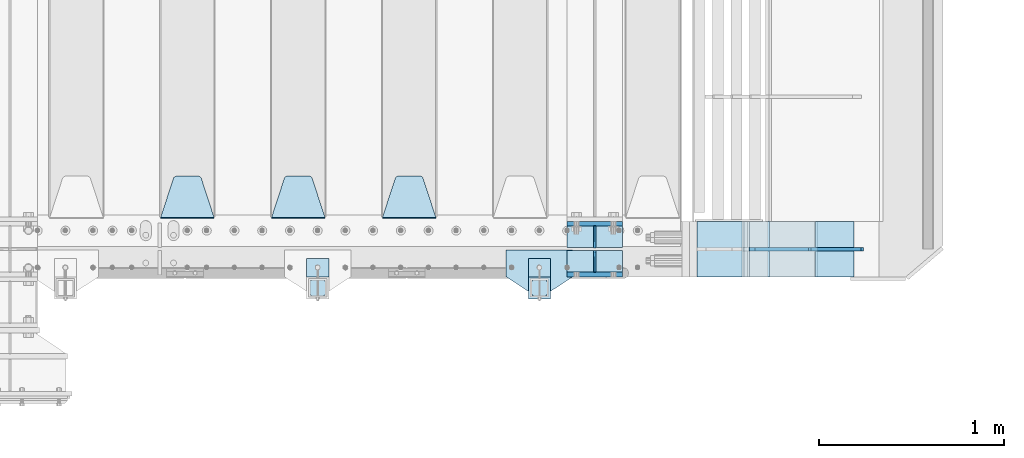
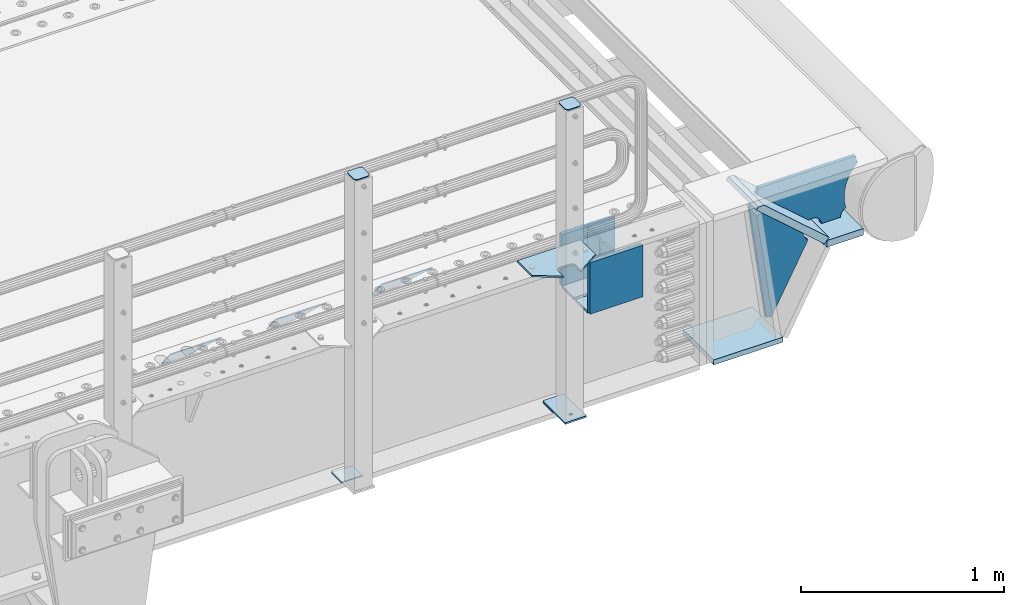
# One storey, part 201 of 240: 20 plates.
"""IFC2X3 building model written with IfcOpenShell, lengths in millimetres."""

from ifc_helpers import new_model, si_unit, frame, origin_with_axes, place, context, subcontext, project, spatial, faceted_brep, material, type_object, element, save


model = new_model("IFC2X3")

# Units and contexts
model_context = context("Model", 3, precision=1e-05, world=origin_with_axes())
body_context = subcontext(model_context, "Body", "Model", "MODEL_VIEW")
ifc_project = project(units=[si_unit("LENGTHUNIT", "METRE", prefix="MILLI"), si_unit("AREAUNIT", "SQUARE_METRE"), si_unit("VOLUMEUNIT", "CUBIC_METRE"), si_unit("MASSUNIT", "GRAM", prefix="KILO"), si_unit("TIMEUNIT", "SECOND"), si_unit("PLANEANGLEUNIT", "RADIAN"), si_unit("SOLIDANGLEUNIT", "STERADIAN"), si_unit("THERMODYNAMICTEMPERATUREUNIT", "DEGREE_CELSIUS"), si_unit("LUMINOUSINTENSITYUNIT", "LUMEN")], contexts=[model_context])

# Site, building, storey
site_placement = place(None, origin_with_axes())
site = spatial("IfcSite", under=ifc_project, at=site_placement, CompositionType="ELEMENT")
building_placement = place(site_placement, origin_with_axes())
building = spatial("IfcBuilding", under=site, at=building_placement, Name="Standard", CompositionType="ELEMENT")
storey_placement = place(building_placement, origin_with_axes())
storey = spatial("IfcBuildingStorey", under=building, at=storey_placement, Name="Undefined", CompositionType="ELEMENT", Elevation=0.0)

# Plates
ifc_material_1 = material(Name="STEEL/S355N")
plate_type_1 = type_object("IfcPlateType", PredefinedType="NOTDEFINED")
for number, where, z_axis, x_axis in (
    (1, (55855.0, 23862.5, -339.999999999995), (0.0, 0.0, 1.0), (1.0, 0.0, 0.0)),
    (2, (55855.0, 24137.5, -339.999999999995), (0.0, 0.0, 1.0), (1.0, 0.0, 0.0)),
):
    element("IfcPlate", number, at=place(storey_placement, frame(where, z_axis=z_axis, x_axis=x_axis)), inside=storey, type_object=plate_type_1, material=ifc_material_1, context=body_context, shape_type="Brep", body=[
        faceted_brep([(0.0, -12.5, 0.0), (0.0, -12.5, 310.0), (0.0, 12.5, 310.0), (0.0, 12.5, 0.0), (300.0, -12.5, 310.0), (300.0, 12.5, 310.0), (300.0, -12.5, 0.0), (300.0, 12.5, 0.0)], [[[0, 1, 2, 3]], [[1, 4, 5, 2]], [[4, 6, 7, 5]], [[6, 0, 3, 7]], [[5, 7, 3, 2]], [[6, 4, 1, 0]]]),
    ])
plate_type_2 = type_object("IfcPlateType", PredefinedType="NOTDEFINED")
for number, where, z_axis, x_axis in (
    (3, (55855.0, 24008.0, -342.999999999995), (0.0, 1.0, 0.0), (1.0, 0.0, 0.0)),
    (4, (55855.0, 23992.0, -342.999999999995), (0.0, -1.0, 0.0), (1.0, 0.0, 0.0)),
):
    element("IfcPlate", number, at=place(storey_placement, frame(where, z_axis=z_axis, x_axis=x_axis)), inside=storey, type_object=plate_type_2, material=ifc_material_1, context=body_context, shape_type="Brep", body=[
        faceted_brep([(0.0, -7.0, 0.0), (0.0, -7.0, 117.0), (0.0, 7.0, 117.0), (0.0, 7.0, 0.0), (300.0, -7.0, 117.0), (300.0, 7.0, 117.0), (300.0, -7.0, 0.0), (300.0, 7.0, 0.0)], [[[0, 1, 2, 3]], [[1, 4, 5, 2]], [[4, 6, 7, 5]], [[6, 0, 3, 7]], [[5, 7, 3, 2]], [[6, 4, 1, 0]]]),
    ])
plate_type_3 = type_object("IfcPlateType", PredefinedType="NOTDEFINED")
for number, where, z_axis, x_axis in (
    (5, (56005.0, 23992.0, -29.9999999999945), (0.0, 0.0, -1.0), (0.0, -1.0, 0.0)),
    (6, (56005.0, 24008.0, -29.9999999999945), (0.0, 0.0, -1.0), (0.0, 1.0, 0.0)),
):
    element("IfcPlate", number, at=place(storey_placement, frame(where, z_axis=z_axis, x_axis=x_axis)), inside=storey, type_object=plate_type_3, material=ifc_material_1, context=body_context, shape_type="Brep", body=[
        faceted_brep([(0.0, -5.0, 30.0), (0.0, -5.0, 306.0), (0.0, 5.0, 306.0), (0.0, 5.0, 30.0), (117.0, -5.0, 306.0), (117.0, 5.0, 306.0), (117.0, -5.0, 0.0), (117.0, 5.0, 0.0), (30.0, -5.0, 0.0), (30.0, 5.0, 0.0), (24.7905546699913, -5.0, 0.455767409633758), (24.7905546699913, 5.0, 0.455767409633758), (19.7393957002278, -5.0, 1.80922137642275), (19.7393957002278, 5.0, 1.80922137642275), (15.0, -5.0, 4.01923788646684), (15.0, 5.0, 4.01923788646684), (10.7163717094008, -5.0, 7.01866670643066), (10.7163717094008, 5.0, 7.01866670643066), (7.01866670643358, -5.0, 10.7163717094038), (7.01866670643358, 5.0, 10.7163717094038), (4.01923788646673, -5.0, 15.0), (4.01923788646673, 5.0, 15.0), (1.80922137642483, -5.0, 19.7393957002299), (1.80922137642483, 5.0, 19.7393957002299), (0.455767409635882, -5.0, 24.7905546699921), (0.455767409635882, 5.0, 24.7905546699921)], [[[0, 1, 2, 3]], [[1, 4, 5, 2]], [[4, 6, 7, 5]], [[6, 8, 9, 7]], [[8, 10, 11, 9]], [[10, 12, 13, 11]], [[12, 14, 15, 13]], [[14, 16, 17, 15]], [[16, 18, 19, 17]], [[18, 20, 21, 19]], [[20, 22, 23, 21]], [[22, 24, 25, 23]], [[24, 0, 3, 25]], [[5, 7, 9, 11, 13, 15, 17, 19, 21, 23, 25, 3, 2]], [[24, 22, 20, 18, 16, 14, 12, 10, 8, 6, 4, 1, 0]]]),
    ])
plate_type_4 = type_object("IfcPlateType", PredefinedType="NOTDEFINED")
plate_1_placement = place(storey_placement, frame((55145.0, 24168.232233047, -1.76776695296758), z_axis=(0.0, 0.707106781186547, -0.707106781186548), x_axis=(-1.0, 0.0, 0.0)))
element("IfcPlate", 7, at=plate_1_placement, inside=storey, type_object=plate_type_4, material=ifc_material_1, context=body_context, shape_type="Brep", body=[
    faceted_brep([(0.0, -2.5, 0.0), (69.345504679477, -2.50000000000364, 300.171731424827), (69.345504679477, 2.49999999999636, 300.171731424827), (0.0, 2.5, 0.0), (70.927406119954, -2.50000000000364, 304.897442415397), (70.927406119954, 2.49999999999636, 304.897442415397), (73.3818627772271, -2.50000000000728, 309.234538108525), (73.3818627772271, 2.49999999999636, 309.234538108529), (76.6187032999587, -2.50000000000728, 313.023683126099), (76.6187032999587, 2.49999999999636, 313.023683126103), (80.5190132705029, -2.50000000000364, 316.125672595368), (80.5190132705029, 2.49999999999636, 316.125672595368), (84.9395038596849, -2.50000000000364, 318.426546230472), (84.9395038596849, 2.49999999999636, 318.426546230472), (89.7177759439219, -2.5, 319.841774983277), (89.7177759439219, 2.49999999999636, 319.841774983273), (94.6782862926484, -2.50000000000364, 320.319366455074), (94.6782862926484, 2.49999999999636, 320.319366455074), (195.321713707352, -2.50000000000364, 320.319366455074), (195.321713707352, 2.49999999999636, 320.319366455074), (200.282224056078, -2.50000000000364, 319.841774983273), (200.282224056078, 2.49999999999636, 319.841774983273), (205.060496140315, -2.50000000000364, 318.426546230472), (205.060496140315, 2.49999999999636, 318.426546230472), (209.480986729497, -2.50000000000364, 316.125672595368), (209.480986729497, 2.49999999999636, 316.125672595368), (213.381296700041, -2.50000000000728, 313.023683126099), (213.381296700041, 2.49999999999272, 313.023683126099), (216.618137222766, -2.50000000000364, 309.234538108522), (216.618137222766, 2.49999999999636, 309.234538108522), (219.072593880039, -2.50000000000364, 304.897442415397), (219.072593880039, 2.49999999999636, 304.897442415397), (220.654495320523, -2.50000000000364, 300.171731424827), (220.654495320523, 2.49999999999636, 300.171731424827), (290.0, -2.50000000000364, -3.63797880709171e-12), (290.0, 2.49999999999636, -3.63797880709171e-12)], [[[0, 1, 2, 3]], [[1, 4, 5, 2]], [[4, 6, 7, 5]], [[6, 8, 9, 7]], [[8, 10, 11, 9]], [[10, 12, 13, 11]], [[12, 14, 15, 13]], [[14, 16, 17, 15]], [[16, 18, 19, 17]], [[18, 20, 21, 19]], [[20, 22, 23, 21]], [[22, 24, 25, 23]], [[24, 26, 27, 25]], [[26, 28, 29, 27]], [[28, 30, 31, 29]], [[30, 32, 33, 31]], [[32, 34, 35, 33]], [[34, 0, 3, 35]], [[5, 7, 9, 11, 13, 15, 17, 19, 21, 23, 25, 27, 29, 31, 33, 35, 3, 2]], [[34, 32, 30, 28, 26, 24, 22, 20, 18, 16, 14, 12, 10, 8, 6, 4, 1, 0]]]),
])
plate_2_placement = place(storey_placement, frame((54545.0, 24168.232233047, -1.76776695296758), z_axis=(0.0, 0.707106781186547, -0.707106781186548), x_axis=(-1.0, 0.0, 0.0)))
element("IfcPlate", 8, at=plate_2_placement, inside=storey, type_object=plate_type_4, material=ifc_material_1, context=body_context, shape_type="Brep", body=[
    faceted_brep([(0.0, -2.5, 0.0), (69.345504679477, -2.50000000000364, 300.171731424827), (69.345504679477, 2.49999999999636, 300.171731424827), (0.0, 2.5, 0.0), (70.927406119954, -2.50000000000364, 304.897442415397), (70.927406119954, 2.49999999999636, 304.897442415397), (73.3818627772271, -2.50000000000728, 309.234538108525), (73.3818627772271, 2.49999999999636, 309.234538108529), (76.6187032999587, -2.50000000000728, 313.023683126099), (76.6187032999587, 2.49999999999636, 313.023683126103), (80.5190132705029, -2.50000000000364, 316.125672595368), (80.5190132705029, 2.49999999999636, 316.125672595368), (84.9395038596849, -2.50000000000364, 318.426546230472), (84.9395038596849, 2.49999999999636, 318.426546230472), (89.7177759439219, -2.5, 319.841774983277), (89.7177759439219, 2.49999999999636, 319.841774983273), (94.6782862926484, -2.50000000000364, 320.319366455074), (94.6782862926484, 2.49999999999636, 320.319366455074), (195.321713707352, -2.50000000000364, 320.319366455074), (195.321713707352, 2.49999999999636, 320.319366455074), (200.282224056078, -2.50000000000364, 319.841774983273), (200.282224056078, 2.49999999999636, 319.841774983273), (205.060496140315, -2.50000000000364, 318.426546230472), (205.060496140315, 2.49999999999636, 318.426546230472), (209.480986729497, -2.50000000000364, 316.125672595368), (209.480986729497, 2.49999999999636, 316.125672595368), (213.381296700041, -2.50000000000728, 313.023683126099), (213.381296700041, 2.49999999999272, 313.023683126099), (216.618137222766, -2.50000000000364, 309.234538108522), (216.618137222766, 2.49999999999636, 309.234538108522), (219.072593880039, -2.50000000000364, 304.897442415397), (219.072593880039, 2.49999999999636, 304.897442415397), (220.654495320523, -2.50000000000364, 300.171731424827), (220.654495320523, 2.49999999999636, 300.171731424827), (290.0, -2.50000000000364, -3.63797880709171e-12), (290.0, 2.49999999999636, -3.63797880709171e-12)], [[[0, 1, 2, 3]], [[1, 4, 5, 2]], [[4, 6, 7, 5]], [[6, 8, 9, 7]], [[8, 10, 11, 9]], [[10, 12, 13, 11]], [[12, 14, 15, 13]], [[14, 16, 17, 15]], [[16, 18, 19, 17]], [[18, 20, 21, 19]], [[20, 22, 23, 21]], [[22, 24, 25, 23]], [[24, 26, 27, 25]], [[26, 28, 29, 27]], [[28, 30, 31, 29]], [[30, 32, 33, 31]], [[32, 34, 35, 33]], [[34, 0, 3, 35]], [[5, 7, 9, 11, 13, 15, 17, 19, 21, 23, 25, 27, 29, 31, 33, 35, 3, 2]], [[34, 32, 30, 28, 26, 24, 22, 20, 18, 16, 14, 12, 10, 8, 6, 4, 1, 0]]]),
])
plate_3_placement = place(storey_placement, frame((53945.0, 24168.232233047, -1.76776695296758), z_axis=(0.0, 0.707106781186547, -0.707106781186548), x_axis=(-1.0, 0.0, 0.0)))
element("IfcPlate", 9, at=plate_3_placement, inside=storey, type_object=plate_type_4, material=ifc_material_1, context=body_context, shape_type="Brep", body=[
    faceted_brep([(0.0, -2.5, 0.0), (69.345504679477, -2.50000000000364, 300.171731424827), (69.345504679477, 2.49999999999636, 300.171731424827), (0.0, 2.5, 0.0), (70.927406119954, -2.50000000000364, 304.897442415397), (70.927406119954, 2.49999999999636, 304.897442415397), (73.3818627772271, -2.50000000000728, 309.234538108525), (73.3818627772271, 2.49999999999636, 309.234538108529), (76.6187032999587, -2.50000000000728, 313.023683126099), (76.6187032999587, 2.49999999999636, 313.023683126103), (80.5190132705029, -2.50000000000364, 316.125672595368), (80.5190132705029, 2.49999999999636, 316.125672595368), (84.9395038596849, -2.50000000000364, 318.426546230472), (84.9395038596849, 2.49999999999636, 318.426546230472), (89.7177759439219, -2.5, 319.841774983277), (89.7177759439219, 2.49999999999636, 319.841774983273), (94.6782862926484, -2.50000000000364, 320.319366455074), (94.6782862926484, 2.49999999999636, 320.319366455074), (195.321713707352, -2.50000000000364, 320.319366455074), (195.321713707352, 2.49999999999636, 320.319366455074), (200.282224056078, -2.50000000000364, 319.841774983273), (200.282224056078, 2.49999999999636, 319.841774983273), (205.060496140315, -2.50000000000364, 318.426546230472), (205.060496140315, 2.49999999999636, 318.426546230472), (209.480986729497, -2.50000000000364, 316.125672595368), (209.480986729497, 2.49999999999636, 316.125672595368), (213.381296700041, -2.50000000000728, 313.023683126099), (213.381296700041, 2.49999999999272, 313.023683126099), (216.618137222766, -2.50000000000364, 309.234538108522), (216.618137222766, 2.49999999999636, 309.234538108522), (219.072593880039, -2.50000000000364, 304.897442415397), (219.072593880039, 2.49999999999636, 304.897442415397), (220.654495320523, -2.50000000000364, 300.171731424827), (220.654495320523, 2.49999999999636, 300.171731424827), (290.0, -2.50000000000364, -3.63797880709171e-12), (290.0, 2.49999999999636, -3.63797880709171e-12)], [[[0, 1, 2, 3]], [[1, 4, 5, 2]], [[4, 6, 7, 5]], [[6, 8, 9, 7]], [[8, 10, 11, 9]], [[10, 12, 13, 11]], [[12, 14, 15, 13]], [[14, 16, 17, 15]], [[16, 18, 19, 17]], [[18, 20, 21, 19]], [[20, 22, 23, 21]], [[22, 24, 25, 23]], [[24, 26, 27, 25]], [[26, 28, 29, 27]], [[28, 30, 31, 29]], [[30, 32, 33, 31]], [[32, 34, 35, 33]], [[34, 0, 3, 35]], [[5, 7, 9, 11, 13, 15, 17, 19, 21, 23, 25, 27, 29, 31, 33, 35, 3, 2]], [[34, 32, 30, 28, 26, 24, 22, 20, 18, 16, 14, 12, 10, 8, 6, 4, 1, 0]]]),
])
plate_type_5 = type_object("IfcPlateType", PredefinedType="NOTDEFINED")
plate_4_placement = place(storey_placement, frame((57198.9988298899, 24149.9999999992, -367.999999998666), z_axis=(-0.752989422949573, 0.0, 0.658032619955933), x_axis=(0.0, -1.0, 0.0)))
element("IfcPlate", 10, at=plate_4_placement, inside=storey, type_object=plate_type_5, material=ifc_material_1, context=body_context, shape_type="Brep", body=[
    faceted_brep([(-8.11269273981452e-10, 19.9999999999927, 490.766265601618), (0.0, -0.303811250945728, 514.0), (300.0, -0.303811250945728, 514.0), (300.0, 19.9999999999927, 490.766265601618), (300.0, -20.0, -1.81898940354586e-12), (300.0, -20.0, 514.0), (0.0, -20.0, 514.0), (0.0, -20.0, 0.0), (0.0, 20.0, 0.0), (300.0, 20.0, -1.81898940354586e-12)], [[[0, 1, 2, 3]], [[4, 5, 6, 7]], [[4, 7, 8, 9]], [[9, 8, 0, 3]], [[5, 4, 9, 3, 2]], [[6, 5, 2, 1]], [[8, 7, 6, 1, 0]]]),
])
ifc_material_2 = material(Name="STEEL/S355J2")
plate_type_6 = type_object("IfcPlateType", PredefinedType="NOTDEFINED")
plate_5_placement = place(storey_placement, frame((55885.0, 23995.0, 5.00000000004911), z_axis=(0.0, -1.0, 0.0), x_axis=(-1.0, 0.0, 0.0)))
element("IfcPlate", 11, at=plate_5_placement, inside=storey, type_object=plate_type_6, material=ifc_material_2, context=body_context, shape_type="Brep", body=[
    faceted_brep([(0.0, -5.0, 0.0), (2.31396552408114e-06, -5.0, 145.0), (2.31396552408114e-06, 5.0, 145.0), (0.0, 5.0, 0.0), (130.0, -5.0, 230.0), (130.0, 5.0, 230.0), (130.0, -5.0, 180.0), (130.0, 5.0, 180.0), (130.48036798992, -5.0, 175.122741949599), (130.48036798992, 5.0, 175.122741949599), (131.903011687216, -5.0, 170.432914190875), (131.903011687216, 5.0, 170.432914190875), (134.213259692435, -5.0, 166.110744174512), (134.213259692435, 5.0, 166.110744174512), (137.322330470335, -5.0, 162.322330470335), (137.322330470335, 5.0, 162.322330470335), (141.110744174512, -5.0, 159.213259692435), (141.110744174512, 5.0, 159.213259692435), (145.432914190875, -5.0, 156.903011687216), (145.432914190875, 5.0, 156.903011687216), (150.122741949599, -5.0, 155.48036798992), (150.122741949599, 5.0, 155.48036798992), (155.0, -5.0, 155.0), (155.0, 5.0, 155.0), (205.0, -5.0, 155.0), (205.0, 5.0, 155.0), (209.877258050401, -5.0, 155.48036798992), (209.877258050401, 5.0, 155.48036798992), (214.567085809125, -5.0, 156.903011687216), (214.567085809125, 5.0, 156.903011687216), (218.889255825488, -5.0, 159.213259692435), (218.889255825488, 5.0, 159.213259692435), (222.677669529665, -5.0, 162.322330470335), (222.677669529665, 5.0, 162.322330470335), (225.786740307565, -5.0, 166.110744174512), (225.786740307565, 5.0, 166.110744174512), (228.096988312784, -5.0, 170.432914190875), (228.096988312784, 5.0, 170.432914190875), (229.51963201008, -5.0, 175.122741949599), (229.51963201008, 5.0, 175.122741949599), (230.0, -5.0, 180.0), (230.0, 5.0, 180.0), (230.0, -5.0, 230.0), (230.0, 5.0, 230.0), (360.0, -5.0, 145.0), (360.0, 5.0, 145.0), (360.0, -5.0, -7.27595761418343e-12), (360.0, 5.0, -7.27595761418343e-12)], [[[0, 1, 2, 3]], [[1, 4, 5, 2]], [[4, 6, 7, 5]], [[6, 8, 9, 7]], [[8, 10, 11, 9]], [[10, 12, 13, 11]], [[12, 14, 15, 13]], [[14, 16, 17, 15]], [[16, 18, 19, 17]], [[18, 20, 21, 19]], [[20, 22, 23, 21]], [[22, 24, 25, 23]], [[24, 26, 27, 25]], [[26, 28, 29, 27]], [[28, 30, 31, 29]], [[30, 32, 33, 31]], [[32, 34, 35, 33]], [[34, 36, 37, 35]], [[36, 38, 39, 37]], [[38, 40, 41, 39]], [[40, 42, 43, 41]], [[42, 44, 45, 43]], [[44, 46, 47, 45]], [[46, 0, 3, 47]], [[5, 7, 9, 11, 13, 15, 17, 19, 21, 23, 25, 27, 29, 31, 33, 35, 37, 39, 41, 43, 45, 47, 3, 2]], [[46, 44, 42, 40, 38, 36, 34, 32, 30, 28, 26, 24, 22, 20, 18, 16, 14, 12, 10, 8, 6, 4, 1, 0]]]),
])
plate_type_7 = type_object("IfcPlateType", PredefinedType="NOTDEFINED")
plate_6_placement = place(storey_placement, frame((55764.9999999999, 23949.9999999998, -850.000000000002), z_axis=(0.0, -1.0, 0.0), x_axis=(-1.0, 0.0, 0.0)))
element("IfcPlate", 12, at=plate_6_placement, inside=storey, type_object=plate_type_7, material=ifc_material_2, context=body_context, shape_type="Brep", body=[
    faceted_brep([(53.6360389691836, -5.0, 176.363961030467), (53.6360389691836, 5.0, 176.363961030467), (59.9999999998618, 5.0, 178.999999999789), (59.9999999998618, -5.0, 178.999999999789), (66.3639610305399, 5.0, 176.363961030467), (66.3639610305399, -5.0, 176.363961030467), (68.9999999998618, 5.0, 169.999999999789), (68.9999999998618, -5.0, 169.999999999789), (66.3639610305399, 5.0, 163.636038969111), (66.3639610305399, -5.0, 163.636038969111), (59.9999999998618, 5.0, 160.999999999789), (59.9999999998618, -5.0, 160.999999999789), (53.6360389691836, 5.0, 163.636038969111), (53.6360389691836, -5.0, 163.636038969111), (50.9999999998618, 5.0, 169.999999999789), (50.9999999998618, -5.0, 169.999999999789), (120.0, -5.0, 0.0), (120.0, -5.0, 220.0), (0.0, -5.0, 220.0), (0.0, -5.0, 0.0), (0.0, 5.0, 0.0), (120.0, 5.0, 0.0), (120.0, 5.0, 220.0), (0.0, 5.0, 220.0)], [[[0, 1, 2, 3]], [[3, 2, 4, 5]], [[5, 4, 6, 7]], [[7, 6, 8, 9]], [[9, 8, 10, 11]], [[11, 10, 12, 13]], [[13, 12, 14, 15]], [[15, 14, 1, 0]], [[16, 17, 18, 19], [11, 13, 15, 0, 3, 5, 7, 9]], [[16, 19, 20, 21]], [[17, 16, 21, 22]], [[18, 17, 22, 23]], [[19, 18, 23, 20]], [[22, 21, 20, 23], [2, 1, 14, 12, 10, 8, 6, 4]]]),
])
plate_type_8 = type_object("IfcPlateType", PredefinedType="NOTDEFINED")
plate_7_placement = place(storey_placement, frame((55660.9999999999, 23833.9999999998, 1012.50000000001), z_axis=(0.0, -1.0, 0.0), x_axis=(1.0, 0.0, 0.0)))
element("IfcPlate", 13, at=plate_7_placement, inside=storey, type_object=plate_type_8, material=ifc_material_2, context=body_context, shape_type="Brep", body=[
    faceted_brep([(0.0, -2.5, 19.0), (0.0, -2.5, 69.0), (0.0, 2.5, 69.0), (0.0, 2.5, 19.0), (0.476369668547704, -2.5, 73.2278977451715), (0.476369668547704, 2.5, 73.2278977451715), (1.88159150985302, -2.5, 77.2437910432345), (1.88159150985302, 2.5, 77.2437910432345), (4.14520183311106, -2.5, 80.8463062353185), (4.14520183311106, 2.5, 80.8463062353185), (7.15369376468152, -2.5, 83.8547981668889), (7.15369376468152, 2.5, 83.8547981668889), (10.7562089567655, -2.5, 86.118408490147), (10.7562089567655, 2.5, 86.118408490147), (14.7721022548285, -2.5, 87.5236303314523), (14.7721022548285, 2.5, 87.5236303314523), (19.0, -2.5, 88.0), (19.0, 2.5, 88.0), (69.0, -2.5, 88.0), (69.0, 2.5, 88.0), (73.2278977451715, -2.5, 87.5236303314523), (73.2278977451715, 2.5, 87.5236303314523), (77.2437910432345, -2.5, 86.118408490147), (77.2437910432345, 2.5, 86.118408490147), (80.8463062353185, -2.5, 83.8547981668889), (80.8463062353185, 2.5, 83.8547981668889), (83.8547981668889, -2.5, 80.8463062353185), (83.8547981668889, 2.5, 80.8463062353185), (86.118408490147, -2.5, 77.2437910432345), (86.118408490147, 2.5, 77.2437910432345), (87.5236303314523, -2.5, 73.2278977451715), (87.5236303314523, 2.5, 73.2278977451715), (88.0, -2.5, 69.0), (88.0, 2.5, 69.0), (88.0, -2.5, 19.0), (88.0, 2.5, 19.0), (87.5236303314523, -2.5, 14.7721022548285), (87.5236303314523, 2.5, 14.7721022548285), (86.118408490147, -2.5, 10.7562089567655), (86.118408490147, 2.5, 10.7562089567655), (83.8547981668889, -2.5, 7.15369376468152), (83.8547981668889, 2.5, 7.15369376468152), (80.8463062353185, -2.5, 4.14520183311106), (80.8463062353185, 2.5, 4.14520183311106), (77.2437910432345, -2.5, 1.88159150985302), (77.2437910432345, 2.5, 1.88159150985302), (73.2278977451715, -2.5, 0.476369668547704), (73.2278977451715, 2.5, 0.476369668547704), (69.0, -2.5, 0.0), (69.0, 2.5, 0.0), (19.0, -2.5, 0.0), (19.0, 2.5, 0.0), (14.7721022548285, -2.5, 0.476369668547704), (14.7721022548285, 2.5, 0.476369668547704), (10.7562089567655, -2.5, 1.88159150985302), (10.7562089567655, 2.5, 1.88159150985302), (7.15369376468152, -2.5, 4.14520183311106), (7.15369376468152, 2.5, 4.14520183311106), (4.14520183311106, -2.5, 7.15369376468152), (4.14520183311106, 2.5, 7.15369376468152), (1.88159150985302, -2.5, 10.7562089567655), (1.88159150985302, 2.5, 10.7562089567655), (0.476369668547704, -2.5, 14.7721022548285), (0.476369668547704, 2.5, 14.7721022548285)], [[[0, 1, 2, 3]], [[1, 4, 5, 2]], [[4, 6, 7, 5]], [[6, 8, 9, 7]], [[8, 10, 11, 9]], [[10, 12, 13, 11]], [[12, 14, 15, 13]], [[14, 16, 17, 15]], [[16, 18, 19, 17]], [[18, 20, 21, 19]], [[20, 22, 23, 21]], [[22, 24, 25, 23]], [[24, 26, 27, 25]], [[26, 28, 29, 27]], [[28, 30, 31, 29]], [[30, 32, 33, 31]], [[32, 34, 35, 33]], [[34, 36, 37, 35]], [[36, 38, 39, 37]], [[38, 40, 41, 39]], [[40, 42, 43, 41]], [[42, 44, 45, 43]], [[44, 46, 47, 45]], [[46, 48, 49, 47]], [[48, 50, 51, 49]], [[50, 52, 53, 51]], [[52, 54, 55, 53]], [[54, 56, 57, 55]], [[56, 58, 59, 57]], [[58, 60, 61, 59]], [[60, 62, 63, 61]], [[62, 0, 3, 63]], [[5, 7, 9, 11, 13, 15, 17, 19, 21, 23, 25, 27, 29, 31, 33, 35, 37, 39, 41, 43, 45, 47, 49, 51, 53, 55, 57, 59, 61, 63, 3, 2]], [[62, 60, 58, 56, 54, 52, 50, 48, 46, 44, 42, 40, 38, 36, 34, 32, 30, 28, 26, 24, 22, 20, 18, 16, 14, 12, 10, 8, 6, 4, 1, 0]]]),
])
plate_8_placement = place(storey_placement, frame((54460.9999999999, 23833.9999999998, 1012.50000000001), z_axis=(0.0, -1.0, 0.0), x_axis=(1.0, 0.0, 0.0)))
element("IfcPlate", 14, at=plate_8_placement, inside=storey, type_object=plate_type_8, material=ifc_material_2, context=body_context, shape_type="Brep", body=[
    faceted_brep([(0.0, -2.5, 19.0), (0.0, -2.5, 69.0), (0.0, 2.5, 69.0), (0.0, 2.5, 19.0), (0.476369668547704, -2.5, 73.2278977451715), (0.476369668547704, 2.5, 73.2278977451715), (1.88159150985302, -2.5, 77.2437910432345), (1.88159150985302, 2.5, 77.2437910432345), (4.14520183311106, -2.5, 80.8463062353185), (4.14520183311106, 2.5, 80.8463062353185), (7.15369376468152, -2.5, 83.8547981668889), (7.15369376468152, 2.5, 83.8547981668889), (10.7562089567655, -2.5, 86.118408490147), (10.7562089567655, 2.5, 86.118408490147), (14.7721022548285, -2.5, 87.5236303314523), (14.7721022548285, 2.5, 87.5236303314523), (19.0, -2.5, 88.0), (19.0, 2.5, 88.0), (69.0, -2.5, 88.0), (69.0, 2.5, 88.0), (73.2278977451715, -2.5, 87.5236303314523), (73.2278977451715, 2.5, 87.5236303314523), (77.2437910432345, -2.5, 86.118408490147), (77.2437910432345, 2.5, 86.118408490147), (80.8463062353185, -2.5, 83.8547981668889), (80.8463062353185, 2.5, 83.8547981668889), (83.8547981668889, -2.5, 80.8463062353185), (83.8547981668889, 2.5, 80.8463062353185), (86.118408490147, -2.5, 77.2437910432345), (86.118408490147, 2.5, 77.2437910432345), (87.5236303314523, -2.5, 73.2278977451715), (87.5236303314523, 2.5, 73.2278977451715), (88.0, -2.5, 69.0), (88.0, 2.5, 69.0), (88.0, -2.5, 19.0), (88.0, 2.5, 19.0), (87.5236303314523, -2.5, 14.7721022548285), (87.5236303314523, 2.5, 14.7721022548285), (86.118408490147, -2.5, 10.7562089567655), (86.118408490147, 2.5, 10.7562089567655), (83.8547981668889, -2.5, 7.15369376468152), (83.8547981668889, 2.5, 7.15369376468152), (80.8463062353185, -2.5, 4.14520183311106), (80.8463062353185, 2.5, 4.14520183311106), (77.2437910432345, -2.5, 1.88159150985302), (77.2437910432345, 2.5, 1.88159150985302), (73.2278977451715, -2.5, 0.476369668547704), (73.2278977451715, 2.5, 0.476369668547704), (69.0, -2.5, 0.0), (69.0, 2.5, 0.0), (19.0, -2.5, 0.0), (19.0, 2.5, 0.0), (14.7721022548285, -2.5, 0.476369668547704), (14.7721022548285, 2.5, 0.476369668547704), (10.7562089567655, -2.5, 1.88159150985302), (10.7562089567655, 2.5, 1.88159150985302), (7.15369376468152, -2.5, 4.14520183311106), (7.15369376468152, 2.5, 4.14520183311106), (4.14520183311106, -2.5, 7.15369376468152), (4.14520183311106, 2.5, 7.15369376468152), (1.88159150985302, -2.5, 10.7562089567655), (1.88159150985302, 2.5, 10.7562089567655), (0.476369668547704, -2.5, 14.7721022548285), (0.476369668547704, 2.5, 14.7721022548285)], [[[0, 1, 2, 3]], [[1, 4, 5, 2]], [[4, 6, 7, 5]], [[6, 8, 9, 7]], [[8, 10, 11, 9]], [[10, 12, 13, 11]], [[12, 14, 15, 13]], [[14, 16, 17, 15]], [[16, 18, 19, 17]], [[18, 20, 21, 19]], [[20, 22, 23, 21]], [[22, 24, 25, 23]], [[24, 26, 27, 25]], [[26, 28, 29, 27]], [[28, 30, 31, 29]], [[30, 32, 33, 31]], [[32, 34, 35, 33]], [[34, 36, 37, 35]], [[36, 38, 39, 37]], [[38, 40, 41, 39]], [[40, 42, 43, 41]], [[42, 44, 45, 43]], [[44, 46, 47, 45]], [[46, 48, 49, 47]], [[48, 50, 51, 49]], [[50, 52, 53, 51]], [[52, 54, 55, 53]], [[54, 56, 57, 55]], [[56, 58, 59, 57]], [[58, 60, 61, 59]], [[60, 62, 63, 61]], [[62, 0, 3, 63]], [[5, 7, 9, 11, 13, 15, 17, 19, 21, 23, 25, 27, 29, 31, 33, 35, 37, 39, 41, 43, 45, 47, 49, 51, 53, 55, 57, 59, 61, 63, 3, 2]], [[62, 60, 58, 56, 54, 52, 50, 48, 46, 44, 42, 40, 38, 36, 34, 32, 30, 28, 26, 24, 22, 20, 18, 16, 14, 12, 10, 8, 6, 4, 1, 0]]]),
])
plate_type_9 = type_object("IfcPlateType", PredefinedType="NOTDEFINED")
for number, where, z_axis, x_axis in (
    (15, (55764.9999999999, 23949.9999999998, -857.500000000002), (0.0, -1.0, 0.0), (-1.0, 0.0, 0.0)),
    (16, (54564.9999999999, 23949.9999999998, -857.500000000002), (0.0, -1.0, 0.0), (-1.0, 0.0, 0.0)),
):
    element("IfcPlate", number, at=place(storey_placement, frame(where, z_axis=z_axis, x_axis=x_axis)), inside=storey, type_object=plate_type_9, material=ifc_material_2, context=body_context, shape_type="Brep", body=[
        faceted_brep([(0.0, -2.5, 0.0), (0.0, -2.5, 100.0), (0.0, 2.5, 100.0), (0.0, 2.5, 0.0), (120.0, -2.5, 100.0), (120.0, 2.5, 100.0), (120.0, -2.5, 0.0), (120.0, 2.5, 0.0)], [[[0, 1, 2, 3]], [[1, 4, 5, 2]], [[4, 6, 7, 5]], [[6, 0, 3, 7]], [[5, 7, 3, 2]], [[6, 4, 1, 0]]]),
    ])
plate_type_10 = type_object("IfcPlateType", PredefinedType="NOTDEFINED")
plate_9_placement = place(storey_placement, frame((57198.9988298899, 23849.9999999992, -387.999999998666), z_axis=(1.0, 0.0, 0.0), x_axis=(0.0, 1.0, 0.0)))
element("IfcPlate", 17, at=plate_9_placement, inside=storey, type_object=plate_type_10, material=ifc_material_1, context=body_context, shape_type="Brep", body=[
    faceted_brep([(0.0, -20.0, 0.0), (3.31056071445346e-10, -20.0, 208.0), (3.31056071445346e-10, 20.0, 208.0), (0.0, 20.0, 0.0), (300.0, -20.0, 208.0), (300.0, 20.0, 208.0), (300.0, -20.0, -1.81898940354586e-12), (300.0, 20.0, -1.81898940354586e-12)], [[[0, 1, 2, 3]], [[1, 4, 5, 2]], [[4, 6, 7, 5]], [[6, 0, 3, 7]], [[5, 7, 3, 2]], [[6, 4, 1, 0]]]),
])
plate_type_11 = type_object("IfcPlateType", PredefinedType="NOTDEFINED")
plate_10_placement = place(storey_placement, frame((56949.9988298892, 24150.0, -875.000000002617), z_axis=(0.0, -1.0, 0.0), x_axis=(-1.0, 0.0, 0.0)))
element("IfcPlate", 18, at=plate_10_placement, inside=storey, type_object=plate_type_11, material=ifc_material_1, context=body_context, shape_type="Brep", body=[
    faceted_brep([(0.0, -15.0, 0.0), (0.0, -15.0, 300.0), (0.0, 15.0, 300.0), (0.0, 15.0, 0.0), (393.0, -15.0, 300.0), (393.0, 15.0, 300.0), (393.0, -15.0, 0.0), (393.0, 15.0, 0.0)], [[[0, 1, 2, 3]], [[1, 4, 5, 2]], [[4, 6, 7, 5]], [[6, 0, 3, 7]], [[5, 7, 3, 2]], [[6, 4, 1, 0]]]),
])
plate_type_12 = type_object("IfcPlateType", PredefinedType="NOTDEFINED")
plate_11_placement = place(storey_placement, frame((57513.9988298899, 23999.9999999994, -29.9999999986662), z_axis=(-0.000446694000102124, 0.0, -0.99999990023223), x_axis=(-0.99999990023223, 0.0, 0.000446694000103734)))
element("IfcPlate", 19, at=plate_11_placement, inside=storey, type_object=plate_type_12, material=ifc_material_1, context=body_context, shape_type="Brep", body=[
    faceted_brep([(125.007775472986, 10.0, 291.842314882028), (131.755016800053, 10.0, 263.793234614468), (131.755016800053, -10.0, 263.793234614468), (125.007775472986, -10.0, 291.842314882028), (134.899927074475, 10.0, 224.060281342732), (134.899927074475, -10.0, 224.060281342732), (131.79051499522, 10.0, 184.324534302446), (131.79051499522, -10.0, 184.324534302446), (122.503344607205, 10.0, 145.564419461128), (122.503344607205, -10.0, 145.564419461128), (107.267096867748, 10.0, 108.734339483615), (107.267096867748, -10.0, 108.734339483615), (86.4569387623924, 10.0, 74.7411731709829), (86.4569387623924, -10.0, 74.7411731709829), (60.5852854486438, 10.0, 44.4219450946983), (60.5852854486438, -10.0, 44.4219450946983), (56.2519855253122, 10.0, 40.7176084148918), (56.2519855253122, -10.0, 40.7176084148918), (136.409234539125, -10.0, 297.721677540594), (147.386991180589, -10.0, 308.778803581017), (147.386991180589, 10.0, 308.778803581017), (136.409234539125, 10.0, 297.721677540594), (154.42816613277, -10.0, 322.678193223937), (154.42816613277, 10.0, 322.678193223937), (156.849001662988, -10.0, 338.070097995228), (156.849001662988, 10.0, 338.070097995228), (264.849004013297, -10.0, 338.118348049693), (264.849004013297, 10.0, 338.118348049693), (267.628767119553, -10.0, 321.701412969031), (267.628767119553, 10.0, 321.701412969031), (275.645118712178, -10.0, 307.107546191754), (275.645118712178, 10.0, 307.107546191754), (288.009068357213, -10.0, 295.955165748785), (288.009068357213, 10.0, 295.955165748785), (303.34948944753, -10.0, 289.481038692482), (303.34948944753, 10.0, 289.481038692482), (319.965173216937, -10.0, 288.403127172445), (319.965173216937, 10.0, 288.403127172445), (336.013487920238, -10.0, 292.840968489265), (336.013487920238, 10.0, 292.840968489265), (335.869079589851, -10.0, 293.150054931641), (335.869079589851, 10.0, 293.150054931641), (633.937057436444, -10.0, 32.8861672876965), (633.937057436444, 10.0, 32.8861672876965), (628.672097726398, -10.0, 25.6357574923157), (628.672097726398, 10.0, 25.6357574923157), (624.785781531275, -10.0, 17.5620477266101), (624.785781531275, 10.0, 17.5620477266101), (622.402919050612, -10.0, 8.92432757904926), (622.402919050612, 10.0, 8.92432757904926), (621.600036621094, -10.0, -8.74677219542264e-10), (621.600036621094, 10.0, -8.74677219542264e-10), (70.0000000000073, -10.0, -9.84945458526454e-11), (70.0000000000073, 10.0, -9.84945458526454e-11), (67.7728137216618, -10.0, 17.5170123094482), (67.7728137216618, 10.0, 17.5170123094482), (61.2329794214093, -10.0, 33.9193489203215), (61.2329794214093, 10.0, 33.9193489203215)], [[[0, 1, 2, 3]], [[4, 5, 2, 1]], [[6, 7, 5, 4]], [[8, 9, 7, 6]], [[10, 11, 9, 8]], [[12, 13, 11, 10]], [[14, 15, 13, 12]], [[16, 17, 15, 14]], [[18, 19, 20, 21]], [[19, 22, 23, 20]], [[22, 24, 25, 23]], [[24, 26, 27, 25]], [[26, 28, 29, 27]], [[28, 30, 31, 29]], [[30, 32, 33, 31]], [[32, 34, 35, 33]], [[34, 36, 37, 35]], [[36, 38, 39, 37]], [[38, 40, 41, 39]], [[40, 42, 43, 41]], [[42, 44, 45, 43]], [[44, 46, 47, 45]], [[46, 48, 49, 47]], [[48, 50, 51, 49]], [[50, 52, 53, 51]], [[52, 54, 55, 53]], [[54, 56, 57, 55]], [[12, 10, 8, 6, 4, 1, 0, 21, 20, 23, 25, 27, 29, 31, 33, 35, 37, 39, 41, 43, 45, 47, 49, 51, 53, 55, 57, 16, 14]], [[18, 21, 0, 3]], [[56, 54, 52, 50, 48, 46, 44, 42, 40, 38, 36, 34, 32, 30, 28, 26, 24, 22, 19, 18, 3, 2, 5, 7, 9, 11, 13, 15, 17]], [[57, 56, 17, 16]]]),
])
plate_type_13 = type_object("IfcPlateType", PredefinedType="NOTDEFINED")
plate_12_placement = place(storey_placement, frame((57198.0025685035, 24000.000000001, -393.996688203771), z_axis=(-0.658066357015093, 0.0, -0.752959939017266), x_axis=(-0.752959939017268, 0.0, 0.65806635701509)))
element("IfcPlate", 20, at=plate_12_placement, inside=storey, type_object=plate_type_13, material=ifc_material_1, context=body_context, shape_type="Brep", body=[
    faceted_brep([(-11.3595226159669, -10.0, 48.6925173505806), (-112.015767301033, -10.0, 480.154833723624), (-112.015767301033, 10.0, 480.154833723624), (-11.3595226159669, 10.0, 48.6925173505806), (-104.567323293646, -10.0, 482.519601382526), (-104.567323293646, 10.0, 482.519601382526), (-97.5783311600098, -10.0, 486.016090073739), (-97.5783311600098, 10.0, 486.016090073739), (-91.2195220373906, -10.0, 490.558885551647), (-91.2195220373906, 10.0, 490.558885551647), (-85.6462325884277, -10.0, 496.037013783993), (-85.6462325884277, 10.0, 496.037013783993), (447.024482710491, -10.0, 32.8103372896294), (447.024482710491, 10.0, 32.8103372896294), (441.786973010385, -10.0, 25.5709623937219), (441.786973010385, 10.0, 25.5709623937219), (437.921644570124, -10.0, 17.5149526624009), (437.921644570124, 10.0, 17.5149526624009), (435.551940606492, -10.0, 8.89958500531066), (435.551940606492, 10.0, 8.89958500531066), (434.753540039055, -10.0, -5.23868948221207e-10), (434.753540039055, 10.0, -5.23868948221207e-10), (50.0, -10.0, 0.0), (50.0, 10.0, 0.0), (47.7668538974176, -10.0, 14.7759151575083), (47.7668538974176, 10.0, 14.7759151575083), (41.2668932502784, -10.0, 28.231959221237), (41.2668932502784, 10.0, 28.231959221237), (31.080732530012, -10.0, 39.1661596968188), (31.080732530012, 10.0, 39.1661596968188), (18.1182591411416, -10.0, 46.6018098971836), (18.1182591411416, 10.0, 46.6018098971836), (3.53735696079821, -10.0, 49.8747140917258), (3.53735696079821, 10.0, 49.8747140917258)], [[[0, 1, 2, 3]], [[1, 4, 5, 2]], [[4, 6, 7, 5]], [[6, 8, 9, 7]], [[8, 10, 11, 9]], [[10, 12, 13, 11]], [[12, 14, 15, 13]], [[14, 16, 17, 15]], [[16, 18, 19, 17]], [[18, 20, 21, 19]], [[20, 22, 23, 21]], [[22, 24, 25, 23]], [[24, 26, 27, 25]], [[26, 28, 29, 27]], [[28, 30, 31, 29]], [[30, 32, 33, 31]], [[32, 0, 3, 33]], [[5, 7, 9, 11, 13, 15, 17, 19, 21, 23, 25, 27, 29, 31, 33, 3, 2]], [[32, 30, 28, 26, 24, 22, 20, 18, 16, 14, 12, 10, 8, 6, 4, 1, 0]]]),
])

save(model, "model.ifc")
